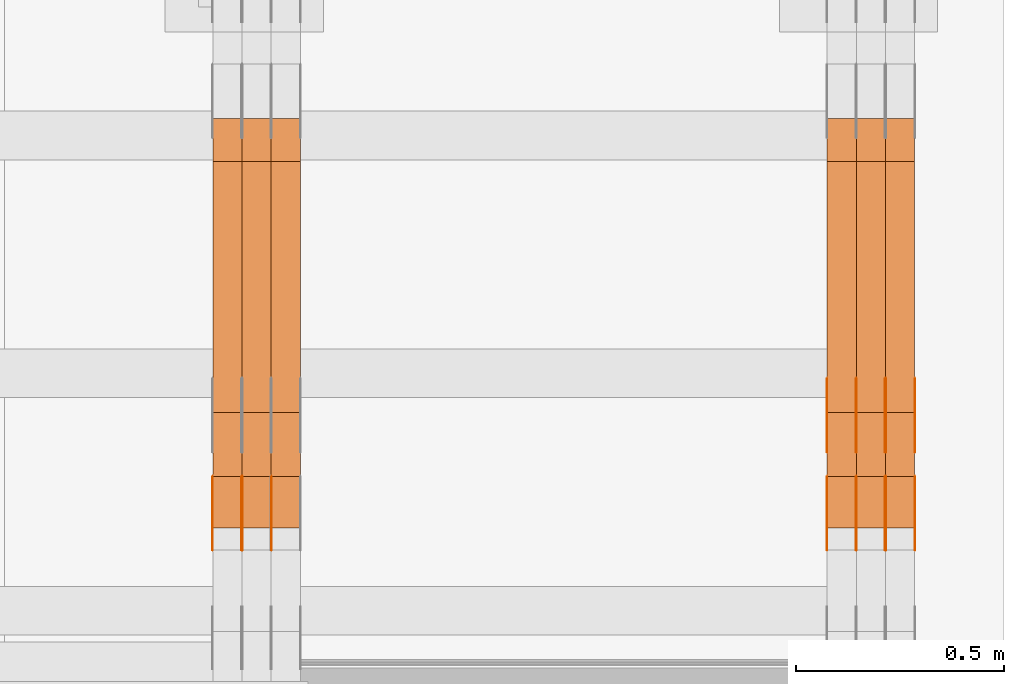
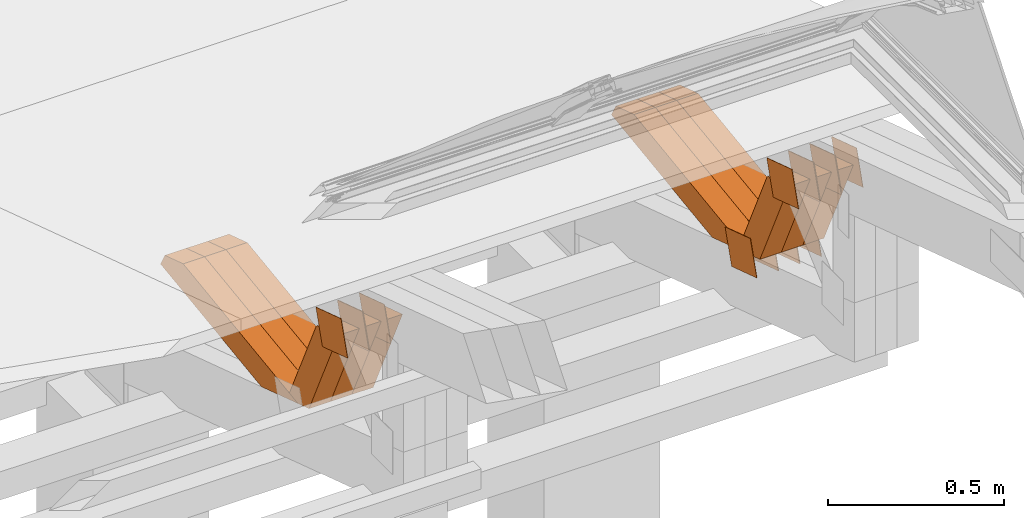
# One storey, part 326 of 385: 28 proxies.
"""IFC2X3 building model written with IfcOpenShell, lengths in millimetres."""

from ifc_helpers import new_model, entity, si_unit, converted_unit, derived_unit, direction, frame, origin, place, context, subcontext, project, spatial, polyline, outline, extrude, source, transform, mapped, material, type_object, type_shapes, element, save


model = new_model("IFC2X3")

# Units and contexts
model_context = context("Model", 3, precision=0.01, world=origin(), true_north=direction((6.12303176911189e-17, 1.0)))
body_context = subcontext(model_context, "Body", "Model", "MODEL_VIEW")
ifc_project = project(units=[si_unit("LENGTHUNIT", "METRE", prefix="MILLI"), si_unit("AREAUNIT", "SQUARE_METRE"), si_unit("VOLUMEUNIT", "CUBIC_METRE"), converted_unit("PLANEANGLEUNIT", "DEGREE", entity("IfcRatioMeasure", 0.0174532925199433), si_unit("PLANEANGLEUNIT", "RADIAN"), dimensions=[0, 0, 0, 0, 0, 0, 0]), si_unit("MASSUNIT", "GRAM", prefix="KILO"), derived_unit("MASSDENSITYUNIT", [(si_unit("MASSUNIT", "GRAM", prefix="KILO"), 1), (si_unit("LENGTHUNIT", "METRE"), -3)]), si_unit("TIMEUNIT", "SECOND"), si_unit("FREQUENCYUNIT", "HERTZ"), si_unit("THERMODYNAMICTEMPERATUREUNIT", "DEGREE_CELSIUS"), derived_unit("THERMALTRANSMITTANCEUNIT", [(si_unit("MASSUNIT", "GRAM", prefix="KILO"), 1), (si_unit("THERMODYNAMICTEMPERATUREUNIT", "KELVIN"), -1), (si_unit("TIMEUNIT", "SECOND"), -3)]), derived_unit("VOLUMETRICFLOWRATEUNIT", [(si_unit("LENGTHUNIT", "METRE"), 3), (si_unit("TIMEUNIT", "SECOND"), -1)]), si_unit("ELECTRICCURRENTUNIT", "AMPERE"), si_unit("ELECTRICVOLTAGEUNIT", "VOLT"), si_unit("POWERUNIT", "WATT"), si_unit("FORCEUNIT", "NEWTON", prefix="KILO"), si_unit("ILLUMINANCEUNIT", "LUX"), si_unit("LUMINOUSFLUXUNIT", "LUMEN"), si_unit("LUMINOUSINTENSITYUNIT", "CANDELA"), derived_unit("USERDEFINED", [(si_unit("MASSUNIT", "GRAM", prefix="KILO"), -1), (si_unit("LENGTHUNIT", "METRE"), -2), (si_unit("TIMEUNIT", "SECOND"), 3), (si_unit("LUMINOUSFLUXUNIT", "LUMEN"), 1)]), derived_unit("LINEARVELOCITYUNIT", [(si_unit("LENGTHUNIT", "METRE"), 1), (si_unit("TIMEUNIT", "SECOND"), -1)]), si_unit("PRESSUREUNIT", "PASCAL"), derived_unit("USERDEFINED", [(si_unit("LENGTHUNIT", "METRE"), -2), (si_unit("MASSUNIT", "GRAM", prefix="KILO"), 1), (si_unit("TIMEUNIT", "SECOND"), -2)])], contexts=[model_context])

# Site, building, storey
site_placement = place(None, origin())
site = spatial("IfcSite", under=ifc_project, at=site_placement, CompositionType="ELEMENT")
building_placement = place(site_placement, origin())
building = spatial("IfcBuilding", under=site, at=building_placement, CompositionType="ELEMENT")
storey_placement = place(building_placement, origin())
storey = spatial("IfcBuildingStorey", under=building, at=storey_placement, Name="Default", CompositionType="ELEMENT", Elevation=0.0)

# Proxies
ifc_material_1 = material(Name="IfcSurfaceStyle #618220")
building_element_proxy_type_1 = type_object("IfcBuildingElementProxyType", PredefinedType="NOTDEFINED", material=ifc_material_1)
shared_shape_1 = source(origin(), body_context, "Body", "SweptSolid", [
    extrude(outline(polyline([(-74.9998605591118, -59.9999264677601), (74.9998754286171, -59.9999264677601), (74.9998605591118, 59.9999264677602), (-74.9998754286171, 59.9999264677602), (-74.9998605591118, -59.9999264677601)])), frame((74.9998754286171, 60.0000503992849, 0.0), z_axis=(0.0, 0.0, 1.0), x_axis=(-1.0, 0.0, 0.0)), (0.0, 0.0, 1.0), 1.3),
])
type_shapes(building_element_proxy_type_1, [shared_shape_1])
proxy_1_placement = place(building_placement, frame((49861.3, 16352.8320303235, 3323.23212676408), z_axis=(-1.0, 0.0, 0.0), x_axis=(0.0, -0.951056516295124, 0.309016994375039)))
element("IfcBuildingElementProxy", 1, at=proxy_1_placement, inside=storey, type_object=building_element_proxy_type_1, material=ifc_material_1, context=body_context, shape_type="MappedRepresentation", body=[
    mapped(shared_shape_1, transform((0.0, 0.0, 0.0), scale=1.0)),
])
ifc_material_2 = material(Name="IfcSurfaceStyle #618163")
building_element_proxy_type_2 = type_object("IfcBuildingElementProxyType", PredefinedType="NOTDEFINED", material=ifc_material_2)
shared_shape_2 = source(origin(), body_context, "Body", "SweptSolid", [
    extrude(outline(polyline([(-74.9998605591118, -59.9999264677601), (74.9998754286171, -59.9999264677601), (74.9998605591118, 59.9999264677602), (-74.9998754286171, 59.9999264677602), (-74.9998605591118, -59.9999264677601)])), frame((74.9998754286171, 60.0000503992849, 0.0), z_axis=(0.0, 0.0, 1.0), x_axis=(-1.0, 0.0, 0.0)), (0.0, 0.0, 1.0), 1.3),
])
type_shapes(building_element_proxy_type_2, [shared_shape_2])
proxy_2_placement = place(building_placement, frame((49790.0, 16352.8320303235, 3323.23212676408), z_axis=(-1.0, 0.0, 0.0), x_axis=(0.0, -0.951056516295124, 0.309016994375039)))
element("IfcBuildingElementProxy", 2, at=proxy_2_placement, inside=storey, type_object=building_element_proxy_type_2, material=ifc_material_2, context=body_context, shape_type="MappedRepresentation", body=[
    mapped(shared_shape_2, transform((0.0, 0.0, 0.0), scale=1.0)),
])
ifc_material_3 = material(Name="IfcSurfaceStyle #618106")
building_element_proxy_type_3 = type_object("IfcBuildingElementProxyType", PredefinedType="NOTDEFINED", material=ifc_material_3)
shared_shape_3 = source(origin(), body_context, "Body", "SweptSolid", [
    extrude(outline(polyline([(-74.9998605591118, -59.9999264677601), (74.9998754286171, -59.9999264677601), (74.9998605591118, 59.9999264677602), (-74.9998754286171, 59.9999264677602), (-74.9998605591118, -59.9999264677601)])), frame((74.9998754286171, 60.0000503992849, 0.0), z_axis=(0.0, 0.0, 1.0), x_axis=(-1.0, 0.0, 0.0)), (0.0, 0.0, 1.0), 1.3),
])
type_shapes(building_element_proxy_type_3, [shared_shape_3])
proxy_3_placement = place(building_placement, frame((49791.3, 16352.8320303235, 3323.23212676408), z_axis=(-1.0, 0.0, 0.0), x_axis=(0.0, -0.951056516295124, 0.309016994375039)))
element("IfcBuildingElementProxy", 3, at=proxy_3_placement, inside=storey, type_object=building_element_proxy_type_3, material=ifc_material_3, context=body_context, shape_type="MappedRepresentation", body=[
    mapped(shared_shape_3, transform((0.0, 0.0, 0.0), scale=1.0)),
])
ifc_material_4 = material(Name="IfcSurfaceStyle #618049")
building_element_proxy_type_4 = type_object("IfcBuildingElementProxyType", PredefinedType="NOTDEFINED", material=ifc_material_4)
shared_shape_4 = source(origin(), body_context, "Body", "SweptSolid", [
    extrude(outline(polyline([(-74.9998605591118, -59.9999264677601), (74.9998754286171, -59.9999264677601), (74.9998605591118, 59.9999264677602), (-74.9998754286171, 59.9999264677602), (-74.9998605591118, -59.9999264677601)])), frame((74.9998754286171, 60.0000503992849, 0.0), z_axis=(0.0, 0.0, 1.0), x_axis=(-1.0, 0.0, 0.0)), (0.0, 0.0, 1.0), 1.29999999999999),
])
type_shapes(building_element_proxy_type_4, [shared_shape_4])
proxy_4_placement = place(building_placement, frame((49720.0, 16352.8320303235, 3323.23212676408), z_axis=(-1.0, 0.0, 0.0), x_axis=(0.0, -0.951056516295124, 0.309016994375039)))
element("IfcBuildingElementProxy", 4, at=proxy_4_placement, inside=storey, type_object=building_element_proxy_type_4, material=ifc_material_4, context=body_context, shape_type="MappedRepresentation", body=[
    mapped(shared_shape_4, transform((0.0, 0.0, 0.0), scale=1.0)),
])
ifc_material_5 = material(Name="IfcSurfaceStyle #617992")
building_element_proxy_type_5 = type_object("IfcBuildingElementProxyType", PredefinedType="NOTDEFINED", material=ifc_material_5)
shared_shape_5 = source(origin(), body_context, "Body", "SweptSolid", [
    extrude(outline(polyline([(-74.9998605591118, -59.9999264677601), (74.9998754286171, -59.9999264677601), (74.9998605591118, 59.9999264677602), (-74.9998754286171, 59.9999264677602), (-74.9998605591118, -59.9999264677601)])), frame((74.9998754286171, 60.0000503992849, 0.0), z_axis=(0.0, 0.0, 1.0), x_axis=(-1.0, 0.0, 0.0)), (0.0, 0.0, 1.0), 1.29999999999999),
])
type_shapes(building_element_proxy_type_5, [shared_shape_5])
proxy_5_placement = place(building_placement, frame((49721.3, 16352.8320303235, 3323.23212676408), z_axis=(-1.0, 0.0, 0.0), x_axis=(0.0, -0.951056516295124, 0.309016994375039)))
element("IfcBuildingElementProxy", 5, at=proxy_5_placement, inside=storey, type_object=building_element_proxy_type_5, material=ifc_material_5, context=body_context, shape_type="MappedRepresentation", body=[
    mapped(shared_shape_5, transform((0.0, 0.0, 0.0), scale=1.0)),
])
ifc_material_6 = material(Name="IfcSurfaceStyle #617935")
building_element_proxy_type_6 = type_object("IfcBuildingElementProxyType", PredefinedType="NOTDEFINED", material=ifc_material_6)
shared_shape_6 = source(origin(), body_context, "Body", "SweptSolid", [
    extrude(outline(polyline([(-74.9998605591118, -59.9999264677601), (74.9998754286171, -59.9999264677601), (74.9998605591118, 59.9999264677602), (-74.9998754286171, 59.9999264677602), (-74.9998605591118, -59.9999264677601)])), frame((74.9998754286171, 60.0000503992849, 0.0), z_axis=(0.0, 0.0, 1.0), x_axis=(-1.0, 0.0, 0.0)), (0.0, 0.0, 1.0), 1.29999999999999),
])
type_shapes(building_element_proxy_type_6, [shared_shape_6])
proxy_6_placement = place(building_placement, frame((49650.0, 16352.8320303235, 3323.23212676408), z_axis=(-1.0, 0.0, 0.0), x_axis=(0.0, -0.951056516295124, 0.309016994375039)))
element("IfcBuildingElementProxy", 6, at=proxy_6_placement, inside=storey, type_object=building_element_proxy_type_6, material=ifc_material_6, context=body_context, shape_type="MappedRepresentation", body=[
    mapped(shared_shape_6, transform((0.0, 0.0, 0.0), scale=1.0)),
])
ifc_material_7 = material(Name="IfcSurfaceStyle #613774")
building_element_proxy_type_7 = type_object("IfcBuildingElementProxyType", PredefinedType="NOTDEFINED", material=ifc_material_7)
shared_shape_7 = source(origin(), body_context, "Body", "SweptSolid", [
    extrude(outline(polyline([(-75.0003249421702, -60.0000773549573), (75.0003398116874, -60.0000773549573), (75.0003249421711, 60.0000773549573), (-75.0003398116883, 60.0000773549573), (-75.0003249421702, -60.0000773549573)])), frame((75.0003398116874, 60.0000773549573, 0.0), z_axis=(0.0, 0.0, 1.0), x_axis=(-1.0, 0.0, 0.0)), (0.0, 0.0, 1.0), 1.3),
])
type_shapes(building_element_proxy_type_7, [shared_shape_7])
proxy_7_placement = place(building_placement, frame((49861.3, 16117.0849050545, 3705.49074668796), z_axis=(-1.0, 0.0, 0.0), x_axis=(0.0, -0.951056516295154, 0.309016994374948)))
element("IfcBuildingElementProxy", 7, at=proxy_7_placement, inside=storey, type_object=building_element_proxy_type_7, material=ifc_material_7, context=body_context, shape_type="MappedRepresentation", body=[
    mapped(shared_shape_7, transform((0.0, 0.0, 0.0), scale=1.0)),
])
ifc_material_8 = material(Name="IfcSurfaceStyle #613717")
building_element_proxy_type_8 = type_object("IfcBuildingElementProxyType", PredefinedType="NOTDEFINED", material=ifc_material_8)
shared_shape_8 = source(origin(), body_context, "Body", "SweptSolid", [
    extrude(outline(polyline([(-75.0003249421702, -60.0000773549573), (75.0003398116874, -60.0000773549573), (75.0003249421711, 60.0000773549573), (-75.0003398116883, 60.0000773549573), (-75.0003249421702, -60.0000773549573)])), frame((75.0003398116874, 60.0000773549573, 0.0), z_axis=(0.0, 0.0, 1.0), x_axis=(-1.0, 0.0, 0.0)), (0.0, 0.0, 1.0), 1.3),
])
type_shapes(building_element_proxy_type_8, [shared_shape_8])
proxy_8_placement = place(building_placement, frame((49790.0, 16117.0849050545, 3705.49074668796), z_axis=(-1.0, 0.0, 0.0), x_axis=(0.0, -0.951056516295154, 0.309016994374948)))
element("IfcBuildingElementProxy", 8, at=proxy_8_placement, inside=storey, type_object=building_element_proxy_type_8, material=ifc_material_8, context=body_context, shape_type="MappedRepresentation", body=[
    mapped(shared_shape_8, transform((0.0, 0.0, 0.0), scale=1.0)),
])
ifc_material_9 = material(Name="IfcSurfaceStyle #613660")
building_element_proxy_type_9 = type_object("IfcBuildingElementProxyType", PredefinedType="NOTDEFINED", material=ifc_material_9)
shared_shape_9 = source(origin(), body_context, "Body", "SweptSolid", [
    extrude(outline(polyline([(-75.0003249421702, -60.0000773549573), (75.0003398116874, -60.0000773549573), (75.0003249421711, 60.0000773549573), (-75.0003398116883, 60.0000773549573), (-75.0003249421702, -60.0000773549573)])), frame((75.0003398116874, 60.0000773549573, 0.0), z_axis=(0.0, 0.0, 1.0), x_axis=(-1.0, 0.0, 0.0)), (0.0, 0.0, 1.0), 1.3),
])
type_shapes(building_element_proxy_type_9, [shared_shape_9])
proxy_9_placement = place(building_placement, frame((49791.3, 16117.0849050545, 3705.49074668796), z_axis=(-1.0, 0.0, 0.0), x_axis=(0.0, -0.951056516295154, 0.309016994374948)))
element("IfcBuildingElementProxy", 9, at=proxy_9_placement, inside=storey, type_object=building_element_proxy_type_9, material=ifc_material_9, context=body_context, shape_type="MappedRepresentation", body=[
    mapped(shared_shape_9, transform((0.0, 0.0, 0.0), scale=1.0)),
])
ifc_material_10 = material(Name="IfcSurfaceStyle #613603")
building_element_proxy_type_10 = type_object("IfcBuildingElementProxyType", PredefinedType="NOTDEFINED", material=ifc_material_10)
shared_shape_10 = source(origin(), body_context, "Body", "SweptSolid", [
    extrude(outline(polyline([(-75.0003249421702, -60.0000773549573), (75.0003398116874, -60.0000773549573), (75.0003249421711, 60.0000773549573), (-75.0003398116883, 60.0000773549573), (-75.0003249421702, -60.0000773549573)])), frame((75.0003398116874, 60.0000773549573, 0.0), z_axis=(0.0, 0.0, 1.0), x_axis=(-1.0, 0.0, 0.0)), (0.0, 0.0, 1.0), 1.29999999999999),
])
type_shapes(building_element_proxy_type_10, [shared_shape_10])
proxy_10_placement = place(building_placement, frame((49720.0, 16117.0849050545, 3705.49074668796), z_axis=(-1.0, 0.0, 0.0), x_axis=(0.0, -0.951056516295154, 0.309016994374948)))
element("IfcBuildingElementProxy", 10, at=proxy_10_placement, inside=storey, type_object=building_element_proxy_type_10, material=ifc_material_10, context=body_context, shape_type="MappedRepresentation", body=[
    mapped(shared_shape_10, transform((0.0, 0.0, 0.0), scale=1.0)),
])
ifc_material_11 = material(Name="IfcSurfaceStyle #613546")
building_element_proxy_type_11 = type_object("IfcBuildingElementProxyType", PredefinedType="NOTDEFINED", material=ifc_material_11)
shared_shape_11 = source(origin(), body_context, "Body", "SweptSolid", [
    extrude(outline(polyline([(-75.0003249421702, -60.0000773549573), (75.0003398116874, -60.0000773549573), (75.0003249421711, 60.0000773549573), (-75.0003398116883, 60.0000773549573), (-75.0003249421702, -60.0000773549573)])), frame((75.0003398116874, 60.0000773549573, 0.0), z_axis=(0.0, 0.0, 1.0), x_axis=(-1.0, 0.0, 0.0)), (0.0, 0.0, 1.0), 1.29999999999999),
])
type_shapes(building_element_proxy_type_11, [shared_shape_11])
proxy_11_placement = place(building_placement, frame((49721.3, 16117.0849050545, 3705.49074668796), z_axis=(-1.0, 0.0, 0.0), x_axis=(0.0, -0.951056516295154, 0.309016994374948)))
element("IfcBuildingElementProxy", 11, at=proxy_11_placement, inside=storey, type_object=building_element_proxy_type_11, material=ifc_material_11, context=body_context, shape_type="MappedRepresentation", body=[
    mapped(shared_shape_11, transform((0.0, 0.0, 0.0), scale=1.0)),
])
ifc_material_12 = material(Name="IfcSurfaceStyle #613489")
building_element_proxy_type_12 = type_object("IfcBuildingElementProxyType", PredefinedType="NOTDEFINED", material=ifc_material_12)
shared_shape_12 = source(origin(), body_context, "Body", "SweptSolid", [
    extrude(outline(polyline([(-75.0003249421702, -60.0000773549573), (75.0003398116874, -60.0000773549573), (75.0003249421711, 60.0000773549573), (-75.0003398116883, 60.0000773549573), (-75.0003249421702, -60.0000773549573)])), frame((75.0003398116874, 60.0000773549573, 0.0), z_axis=(0.0, 0.0, 1.0), x_axis=(-1.0, 0.0, 0.0)), (0.0, 0.0, 1.0), 1.29999999999999),
])
type_shapes(building_element_proxy_type_12, [shared_shape_12])
proxy_12_placement = place(building_placement, frame((49650.0, 16117.0849050545, 3705.49074668796), z_axis=(-1.0, 0.0, 0.0), x_axis=(0.0, -0.951056516295154, 0.309016994374948)))
element("IfcBuildingElementProxy", 12, at=proxy_12_placement, inside=storey, type_object=building_element_proxy_type_12, material=ifc_material_12, context=body_context, shape_type="MappedRepresentation", body=[
    mapped(shared_shape_12, transform((0.0, 0.0, 0.0), scale=1.0)),
])
ifc_material_13 = material(Name="IfcSurfaceStyle #603154")
building_element_proxy_type_13 = type_object("IfcBuildingElementProxyType", Name="T2-W44 603152", PredefinedType="NOTDEFINED", material=ifc_material_13)
shared_shape_13 = source(origin(), body_context, "Body", "SweptSolid", [
    extrude(outline(polyline([(-184.551057772692, -47.4997984945814), (177.527112951531, -47.4997984945814), (162.630077773546, -0.000452497529500495), (118.068221667048, 47.5000247433462), (-273.674354619433, 47.5000247433462), (-184.551057772692, -47.4997984945814)])), frame((177.527112951531, 47.5002721629815, 0.0), z_axis=(0.0, 0.0, 1.0), x_axis=(-1.0, 0.0, 0.0)), (0.0, 0.0, 1.0), 70.0),
])
type_shapes(building_element_proxy_type_13, [shared_shape_13])
proxy_13_placement = place(building_placement, frame((49860.0, 16220.4899216004, 3388.98238154171), z_axis=(-1.0, 0.0, 0.0), x_axis=(0.0, -0.425335045192995, 0.905035965766374)))
element("IfcBuildingElementProxy", 13, at=proxy_13_placement, inside=storey, type_object=building_element_proxy_type_13, material=ifc_material_13, Name="T2-W44", context=body_context, shape_type="MappedRepresentation", body=[
    mapped(shared_shape_13, transform((0.0, 0.0, 0.0), scale=1.0)),
])
ifc_material_14 = material(Name="IfcSurfaceStyle #603088")
building_element_proxy_type_14 = type_object("IfcBuildingElementProxyType", Name="T2-W44 603086", PredefinedType="NOTDEFINED", material=ifc_material_14)
shared_shape_14 = source(origin(), body_context, "Body", "SweptSolid", [
    extrude(outline(polyline([(-184.551057772692, -47.4997984945814), (177.527112951531, -47.4997984945814), (162.630077773546, -0.000452497529500495), (118.068221667048, 47.5000247433462), (-273.674354619433, 47.5000247433462), (-184.551057772692, -47.4997984945814)])), frame((177.527112951531, 47.5002721629815, 0.0), z_axis=(0.0, 0.0, 1.0), x_axis=(-1.0, 0.0, 0.0)), (0.0, 0.0, 1.0), 70.0),
])
type_shapes(building_element_proxy_type_14, [shared_shape_14])
proxy_14_placement = place(building_placement, frame((49790.0, 16220.4899216004, 3388.98238154171), z_axis=(-1.0, 0.0, 0.0), x_axis=(0.0, -0.425335045192995, 0.905035965766374)))
element("IfcBuildingElementProxy", 14, at=proxy_14_placement, inside=storey, type_object=building_element_proxy_type_14, material=ifc_material_14, Name="T2-W44", context=body_context, shape_type="MappedRepresentation", body=[
    mapped(shared_shape_14, transform((0.0, 0.0, 0.0), scale=1.0)),
])
ifc_material_15 = material(Name="IfcSurfaceStyle #603022")
building_element_proxy_type_15 = type_object("IfcBuildingElementProxyType", Name="T2-W44 603020", PredefinedType="NOTDEFINED", material=ifc_material_15)
shared_shape_15 = source(origin(), body_context, "Body", "SweptSolid", [
    extrude(outline(polyline([(-184.551057772692, -47.4997984945814), (177.527112951531, -47.4997984945814), (162.630077773546, -0.000452497529500495), (118.068221667048, 47.5000247433462), (-273.674354619433, 47.5000247433462), (-184.551057772692, -47.4997984945814)])), frame((177.527112951531, 47.5002721629815, 0.0), z_axis=(0.0, 0.0, 1.0), x_axis=(-1.0, 0.0, 0.0)), (0.0, 0.0, 1.0), 70.0),
])
type_shapes(building_element_proxy_type_15, [shared_shape_15])
proxy_15_placement = place(building_placement, frame((49720.0, 16220.4899216004, 3388.98238154171), z_axis=(-1.0, 0.0, 0.0), x_axis=(0.0, -0.425335045192995, 0.905035965766374)))
element("IfcBuildingElementProxy", 15, at=proxy_15_placement, inside=storey, type_object=building_element_proxy_type_15, material=ifc_material_15, Name="T2-W44", context=body_context, shape_type="MappedRepresentation", body=[
    mapped(shared_shape_15, transform((0.0, 0.0, 0.0), scale=1.0)),
])
ifc_material_16 = material(Name="IfcSurfaceStyle #602758")
building_element_proxy_type_16 = type_object("IfcBuildingElementProxyType", Name="T2-W8 602756", PredefinedType="NOTDEFINED", material=ifc_material_16)
shared_shape_16 = source(origin(), body_context, "Body", "SweptSolid", [
    extrude(outline(polyline([(-476.725263324644, -47.5001051695965), (180.672765845439, -47.5001051695965), (279.11020091716, -1.03605560390907e-06), (296.793624402619, 47.5001056876243), (-279.851327840575, 47.5001056876243), (-476.725263324644, -47.5001051695965)])), frame((296.793624402619, 47.5001056876243, 0.0), z_axis=(0.0, 0.0, 1.0), x_axis=(-1.0, 0.0, 0.0)), (0.0, 0.0, 1.0), 70.0),
])
type_shapes(building_element_proxy_type_16, [shared_shape_16])
proxy_16_placement = place(building_placement, frame((49860.0, 17036.40625, 3432.97192382813), z_axis=(-1.0, 0.0, 0.0), x_axis=(0.0, -0.990844046556832, -0.135011389900564)))
element("IfcBuildingElementProxy", 16, at=proxy_16_placement, inside=storey, type_object=building_element_proxy_type_16, material=ifc_material_16, Name="T2-W8", context=body_context, shape_type="MappedRepresentation", body=[
    mapped(shared_shape_16, transform((0.0, 0.0, 0.0), scale=1.0)),
])
ifc_material_17 = material(Name="IfcSurfaceStyle #602692")
building_element_proxy_type_17 = type_object("IfcBuildingElementProxyType", Name="T2-W8 602690", PredefinedType="NOTDEFINED", material=ifc_material_17)
shared_shape_17 = source(origin(), body_context, "Body", "SweptSolid", [
    extrude(outline(polyline([(-476.725263324644, -47.5001051695965), (180.672765845439, -47.5001051695965), (279.11020091716, -1.03605560390907e-06), (296.793624402619, 47.5001056876243), (-279.851327840575, 47.5001056876243), (-476.725263324644, -47.5001051695965)])), frame((296.793624402619, 47.5001056876243, 0.0), z_axis=(0.0, 0.0, 1.0), x_axis=(-1.0, 0.0, 0.0)), (0.0, 0.0, 1.0), 70.0),
])
type_shapes(building_element_proxy_type_17, [shared_shape_17])
proxy_17_placement = place(building_placement, frame((49790.0, 17036.40625, 3432.97192382813), z_axis=(-1.0, 0.0, 0.0), x_axis=(0.0, -0.990844046556832, -0.135011389900564)))
element("IfcBuildingElementProxy", 17, at=proxy_17_placement, inside=storey, type_object=building_element_proxy_type_17, material=ifc_material_17, Name="T2-W8", context=body_context, shape_type="MappedRepresentation", body=[
    mapped(shared_shape_17, transform((0.0, 0.0, 0.0), scale=1.0)),
])
ifc_material_18 = material(Name="IfcSurfaceStyle #602626")
building_element_proxy_type_18 = type_object("IfcBuildingElementProxyType", Name="T2-W8 602624", PredefinedType="NOTDEFINED", material=ifc_material_18)
shared_shape_18 = source(origin(), body_context, "Body", "SweptSolid", [
    extrude(outline(polyline([(-476.725263324644, -47.5001051695965), (180.672765845439, -47.5001051695965), (279.11020091716, -1.03605560390907e-06), (296.793624402619, 47.5001056876243), (-279.851327840575, 47.5001056876243), (-476.725263324644, -47.5001051695965)])), frame((296.793624402619, 47.5001056876243, 0.0), z_axis=(0.0, 0.0, 1.0), x_axis=(-1.0, 0.0, 0.0)), (0.0, 0.0, 1.0), 70.0),
])
type_shapes(building_element_proxy_type_18, [shared_shape_18])
proxy_18_placement = place(building_placement, frame((49720.0, 17036.40625, 3432.97192382813), z_axis=(-1.0, 0.0, 0.0), x_axis=(0.0, -0.990844046556832, -0.135011389900564)))
element("IfcBuildingElementProxy", 18, at=proxy_18_placement, inside=storey, type_object=building_element_proxy_type_18, material=ifc_material_18, Name="T2-W8", context=body_context, shape_type="MappedRepresentation", body=[
    mapped(shared_shape_18, transform((0.0, 0.0, 0.0), scale=1.0)),
])
ifc_material_19 = material(Name="IfcSurfaceStyle #579228")
building_element_proxy_type_19 = type_object("IfcBuildingElementProxyType", PredefinedType="NOTDEFINED", material=ifc_material_19)
shared_shape_19 = source(origin(), body_context, "Body", "SweptSolid", [
    extrude(outline(polyline([(-75.0003249421702, -60.0000773549573), (75.0003398116874, -60.0000773549573), (75.0003249421711, 60.0000773549573), (-75.0003398116883, 60.0000773549573), (-75.0003249421702, -60.0000773549573)])), frame((75.0003398116874, 60.0000773549573, 0.0), z_axis=(0.0, 0.0, 1.0), x_axis=(-1.0, 0.0, 0.0)), (0.0, 0.0, 1.0), 1.3),
])
type_shapes(building_element_proxy_type_19, [shared_shape_19])
proxy_19_placement = place(building_placement, frame((48316.3, 16117.0849050545, 3705.49074668796), z_axis=(-1.0, 0.0, 0.0), x_axis=(0.0, -0.951056516295154, 0.309016994374948)))
element("IfcBuildingElementProxy", 19, at=proxy_19_placement, inside=storey, type_object=building_element_proxy_type_19, material=ifc_material_19, context=body_context, shape_type="MappedRepresentation", body=[
    mapped(shared_shape_19, transform((0.0, 0.0, 0.0), scale=1.0)),
])
ifc_material_20 = material(Name="IfcSurfaceStyle #579171")
building_element_proxy_type_20 = type_object("IfcBuildingElementProxyType", PredefinedType="NOTDEFINED", material=ifc_material_20)
shared_shape_20 = source(origin(), body_context, "Body", "SweptSolid", [
    extrude(outline(polyline([(-75.0003249421702, -60.0000773549573), (75.0003398116874, -60.0000773549573), (75.0003249421711, 60.0000773549573), (-75.0003398116883, 60.0000773549573), (-75.0003249421702, -60.0000773549573)])), frame((75.0003398116874, 60.0000773549573, 0.0), z_axis=(0.0, 0.0, 1.0), x_axis=(-1.0, 0.0, 0.0)), (0.0, 0.0, 1.0), 1.29999999999999),
])
type_shapes(building_element_proxy_type_20, [shared_shape_20])
proxy_20_placement = place(building_placement, frame((48245.0, 16117.0849050545, 3705.49074668796), z_axis=(-1.0, 0.0, 0.0), x_axis=(0.0, -0.951056516295154, 0.309016994374948)))
element("IfcBuildingElementProxy", 20, at=proxy_20_placement, inside=storey, type_object=building_element_proxy_type_20, material=ifc_material_20, context=body_context, shape_type="MappedRepresentation", body=[
    mapped(shared_shape_20, transform((0.0, 0.0, 0.0), scale=1.0)),
])
ifc_material_21 = material(Name="IfcSurfaceStyle #579114")
building_element_proxy_type_21 = type_object("IfcBuildingElementProxyType", PredefinedType="NOTDEFINED", material=ifc_material_21)
shared_shape_21 = source(origin(), body_context, "Body", "SweptSolid", [
    extrude(outline(polyline([(-75.0003249421702, -60.0000773549573), (75.0003398116874, -60.0000773549573), (75.0003249421711, 60.0000773549573), (-75.0003398116883, 60.0000773549573), (-75.0003249421702, -60.0000773549573)])), frame((75.0003398116874, 60.0000773549573, 0.0), z_axis=(0.0, 0.0, 1.0), x_axis=(-1.0, 0.0, 0.0)), (0.0, 0.0, 1.0), 1.29999999999999),
])
type_shapes(building_element_proxy_type_21, [shared_shape_21])
proxy_21_placement = place(building_placement, frame((48246.3, 16117.0849050545, 3705.49074668796), z_axis=(-1.0, 0.0, 0.0), x_axis=(0.0, -0.951056516295154, 0.309016994374948)))
element("IfcBuildingElementProxy", 21, at=proxy_21_placement, inside=storey, type_object=building_element_proxy_type_21, material=ifc_material_21, context=body_context, shape_type="MappedRepresentation", body=[
    mapped(shared_shape_21, transform((0.0, 0.0, 0.0), scale=1.0)),
])
ifc_material_22 = material(Name="IfcSurfaceStyle #579057")
building_element_proxy_type_22 = type_object("IfcBuildingElementProxyType", PredefinedType="NOTDEFINED", material=ifc_material_22)
shared_shape_22 = source(origin(), body_context, "Body", "SweptSolid", [
    extrude(outline(polyline([(-75.0003249421702, -60.0000773549573), (75.0003398116874, -60.0000773549573), (75.0003249421711, 60.0000773549573), (-75.0003398116883, 60.0000773549573), (-75.0003249421702, -60.0000773549573)])), frame((75.0003398116874, 60.0000773549573, 0.0), z_axis=(0.0, 0.0, 1.0), x_axis=(-1.0, 0.0, 0.0)), (0.0, 0.0, 1.0), 1.29999999999999),
])
type_shapes(building_element_proxy_type_22, [shared_shape_22])
proxy_22_placement = place(building_placement, frame((48175.0, 16117.0849050545, 3705.49074668796), z_axis=(-1.0, 0.0, 0.0), x_axis=(0.0, -0.951056516295154, 0.309016994374948)))
element("IfcBuildingElementProxy", 22, at=proxy_22_placement, inside=storey, type_object=building_element_proxy_type_22, material=ifc_material_22, context=body_context, shape_type="MappedRepresentation", body=[
    mapped(shared_shape_22, transform((0.0, 0.0, 0.0), scale=1.0)),
])
ifc_material_23 = material(Name="IfcSurfaceStyle #568722")
building_element_proxy_type_23 = type_object("IfcBuildingElementProxyType", Name="T1-W44 568720", PredefinedType="NOTDEFINED", material=ifc_material_23)
shared_shape_23 = source(origin(), body_context, "Body", "SweptSolid", [
    extrude(outline(polyline([(-184.551057772692, -47.4997984945814), (177.527112951531, -47.4997984945814), (162.630077773546, -0.000452497529500495), (118.068221667048, 47.5000247433462), (-273.674354619433, 47.5000247433462), (-184.551057772692, -47.4997984945814)])), frame((177.527112951531, 47.5002721629815, 0.0), z_axis=(0.0, 0.0, 1.0), x_axis=(-1.0, 0.0, 0.0)), (0.0, 0.0, 1.0), 70.0),
])
type_shapes(building_element_proxy_type_23, [shared_shape_23])
proxy_23_placement = place(building_placement, frame((48385.0, 16220.4899216004, 3388.98238154171), z_axis=(-1.0, 0.0, 0.0), x_axis=(0.0, -0.425335045192995, 0.905035965766374)))
element("IfcBuildingElementProxy", 23, at=proxy_23_placement, inside=storey, type_object=building_element_proxy_type_23, material=ifc_material_23, Name="T1-W44", context=body_context, shape_type="MappedRepresentation", body=[
    mapped(shared_shape_23, transform((0.0, 0.0, 0.0), scale=1.0)),
])
ifc_material_24 = material(Name="IfcSurfaceStyle #568656")
building_element_proxy_type_24 = type_object("IfcBuildingElementProxyType", Name="T1-W44 568654", PredefinedType="NOTDEFINED", material=ifc_material_24)
shared_shape_24 = source(origin(), body_context, "Body", "SweptSolid", [
    extrude(outline(polyline([(-184.551057772692, -47.4997984945814), (177.527112951531, -47.4997984945814), (162.630077773546, -0.000452497529500495), (118.068221667048, 47.5000247433462), (-273.674354619433, 47.5000247433462), (-184.551057772692, -47.4997984945814)])), frame((177.527112951531, 47.5002721629815, 0.0), z_axis=(0.0, 0.0, 1.0), x_axis=(-1.0, 0.0, 0.0)), (0.0, 0.0, 1.0), 70.0),
])
type_shapes(building_element_proxy_type_24, [shared_shape_24])
proxy_24_placement = place(building_placement, frame((48315.0, 16220.4899216004, 3388.98238154171), z_axis=(-1.0, 0.0, 0.0), x_axis=(0.0, -0.425335045192995, 0.905035965766374)))
element("IfcBuildingElementProxy", 24, at=proxy_24_placement, inside=storey, type_object=building_element_proxy_type_24, material=ifc_material_24, Name="T1-W44", context=body_context, shape_type="MappedRepresentation", body=[
    mapped(shared_shape_24, transform((0.0, 0.0, 0.0), scale=1.0)),
])
ifc_material_25 = material(Name="IfcSurfaceStyle #568590")
building_element_proxy_type_25 = type_object("IfcBuildingElementProxyType", Name="T1-W44 568588", PredefinedType="NOTDEFINED", material=ifc_material_25)
shared_shape_25 = source(origin(), body_context, "Body", "SweptSolid", [
    extrude(outline(polyline([(-184.551057772692, -47.4997984945814), (177.527112951531, -47.4997984945814), (162.630077773546, -0.000452497529500495), (118.068221667048, 47.5000247433462), (-273.674354619433, 47.5000247433462), (-184.551057772692, -47.4997984945814)])), frame((177.527112951531, 47.5002721629815, 0.0), z_axis=(0.0, 0.0, 1.0), x_axis=(-1.0, 0.0, 0.0)), (0.0, 0.0, 1.0), 70.0),
])
type_shapes(building_element_proxy_type_25, [shared_shape_25])
proxy_25_placement = place(building_placement, frame((48245.0, 16220.4899216004, 3388.98238154171), z_axis=(-1.0, 0.0, 0.0), x_axis=(0.0, -0.425335045192995, 0.905035965766374)))
element("IfcBuildingElementProxy", 25, at=proxy_25_placement, inside=storey, type_object=building_element_proxy_type_25, material=ifc_material_25, Name="T1-W44", context=body_context, shape_type="MappedRepresentation", body=[
    mapped(shared_shape_25, transform((0.0, 0.0, 0.0), scale=1.0)),
])
ifc_material_26 = material(Name="IfcSurfaceStyle #568326")
building_element_proxy_type_26 = type_object("IfcBuildingElementProxyType", Name="T1-W8 568324", PredefinedType="NOTDEFINED", material=ifc_material_26)
shared_shape_26 = source(origin(), body_context, "Body", "SweptSolid", [
    extrude(outline(polyline([(-476.725263324644, -47.5001051695965), (180.672765845439, -47.5001051695965), (279.11020091716, -1.03605560390907e-06), (296.793624402619, 47.5001056876243), (-279.851327840575, 47.5001056876243), (-476.725263324644, -47.5001051695965)])), frame((296.793624402619, 47.5001056876243, 0.0), z_axis=(0.0, 0.0, 1.0), x_axis=(-1.0, 0.0, 0.0)), (0.0, 0.0, 1.0), 70.0),
])
type_shapes(building_element_proxy_type_26, [shared_shape_26])
proxy_26_placement = place(building_placement, frame((48385.0, 17036.40625, 3432.97192382813), z_axis=(-1.0, 0.0, 0.0), x_axis=(0.0, -0.990844046556832, -0.135011389900564)))
element("IfcBuildingElementProxy", 26, at=proxy_26_placement, inside=storey, type_object=building_element_proxy_type_26, material=ifc_material_26, Name="T1-W8", context=body_context, shape_type="MappedRepresentation", body=[
    mapped(shared_shape_26, transform((0.0, 0.0, 0.0), scale=1.0)),
])
ifc_material_27 = material(Name="IfcSurfaceStyle #568260")
building_element_proxy_type_27 = type_object("IfcBuildingElementProxyType", Name="T1-W8 568258", PredefinedType="NOTDEFINED", material=ifc_material_27)
shared_shape_27 = source(origin(), body_context, "Body", "SweptSolid", [
    extrude(outline(polyline([(-476.725263324644, -47.5001051695965), (180.672765845439, -47.5001051695965), (279.11020091716, -1.03605560390907e-06), (296.793624402619, 47.5001056876243), (-279.851327840575, 47.5001056876243), (-476.725263324644, -47.5001051695965)])), frame((296.793624402619, 47.5001056876243, 0.0), z_axis=(0.0, 0.0, 1.0), x_axis=(-1.0, 0.0, 0.0)), (0.0, 0.0, 1.0), 70.0),
])
type_shapes(building_element_proxy_type_27, [shared_shape_27])
proxy_27_placement = place(building_placement, frame((48315.0, 17036.40625, 3432.97192382813), z_axis=(-1.0, 0.0, 0.0), x_axis=(0.0, -0.990844046556832, -0.135011389900564)))
element("IfcBuildingElementProxy", 27, at=proxy_27_placement, inside=storey, type_object=building_element_proxy_type_27, material=ifc_material_27, Name="T1-W8", context=body_context, shape_type="MappedRepresentation", body=[
    mapped(shared_shape_27, transform((0.0, 0.0, 0.0), scale=1.0)),
])
ifc_material_28 = material(Name="IfcSurfaceStyle #568194")
building_element_proxy_type_28 = type_object("IfcBuildingElementProxyType", Name="T1-W8 568192", PredefinedType="NOTDEFINED", material=ifc_material_28)
shared_shape_28 = source(origin(), body_context, "Body", "SweptSolid", [
    extrude(outline(polyline([(-476.725263324644, -47.5001051695965), (180.672765845439, -47.5001051695965), (279.11020091716, -1.03605560390907e-06), (296.793624402619, 47.5001056876243), (-279.851327840575, 47.5001056876243), (-476.725263324644, -47.5001051695965)])), frame((296.793624402619, 47.5001056876243, 0.0), z_axis=(0.0, 0.0, 1.0), x_axis=(-1.0, 0.0, 0.0)), (0.0, 0.0, 1.0), 70.0),
])
type_shapes(building_element_proxy_type_28, [shared_shape_28])
proxy_28_placement = place(building_placement, frame((48245.0, 17036.40625, 3432.97192382813), z_axis=(-1.0, 0.0, 0.0), x_axis=(0.0, -0.990844046556832, -0.135011389900564)))
element("IfcBuildingElementProxy", 28, at=proxy_28_placement, inside=storey, type_object=building_element_proxy_type_28, material=ifc_material_28, Name="T1-W8", context=body_context, shape_type="MappedRepresentation", body=[
    mapped(shared_shape_28, transform((0.0, 0.0, 0.0), scale=1.0)),
])

save(model, "model.ifc")
